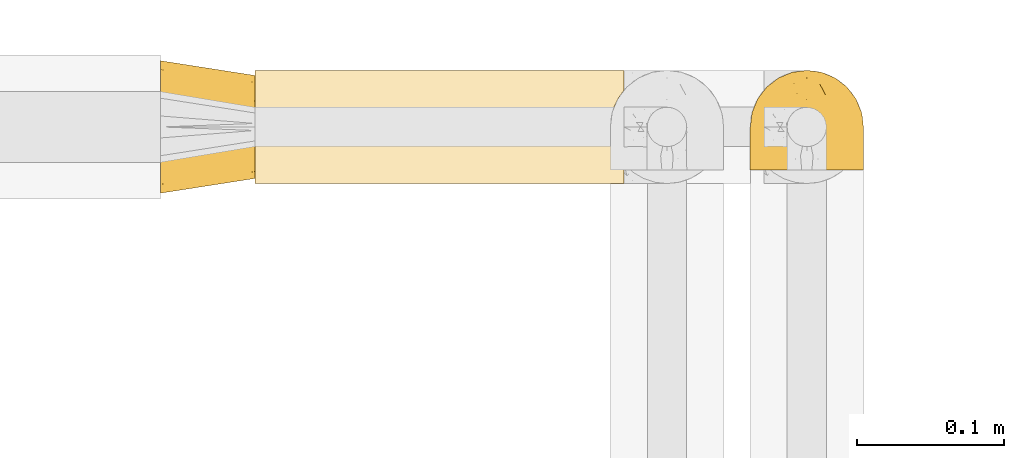
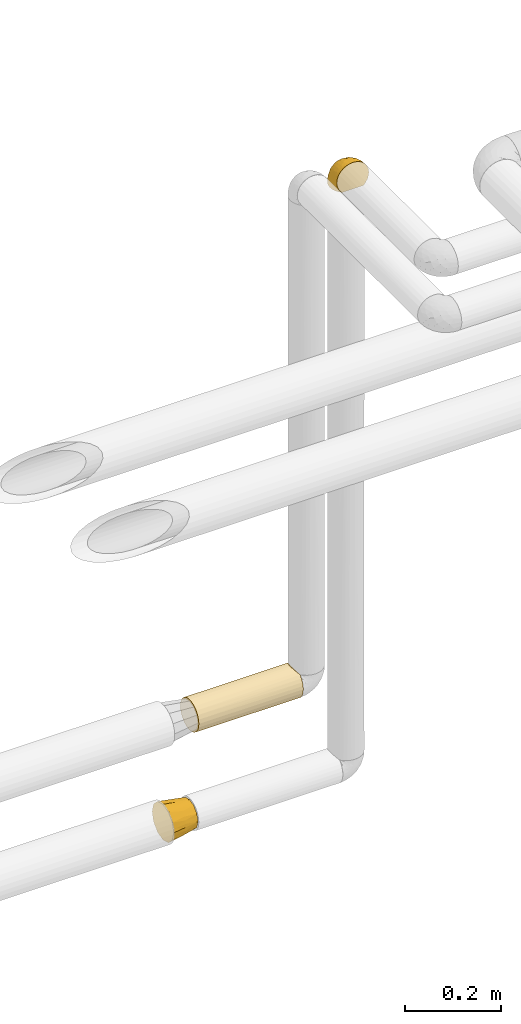
# One storey, part 368 of 827: 3 coverings.
"""IFC2X3 building model written with IfcOpenShell, lengths in millimetres."""

from ifc_helpers import new_model, entity, si_unit, converted_unit, derived_unit, direction, frame, origin, place, context, subcontext, project, spatial, faceted_brep, element, save


model = new_model("IFC2X3")

# Units and contexts
model_context = context("Model", 3, precision=0.01, world=origin(), true_north=direction((6.12303176911189e-17, 1.0)))
body_context = subcontext(model_context, "Body", "Model", "MODEL_VIEW")
ifc_project = project(units=[si_unit("LENGTHUNIT", "METRE", prefix="MILLI"), si_unit("AREAUNIT", "SQUARE_METRE"), si_unit("VOLUMEUNIT", "CUBIC_METRE"), converted_unit("PLANEANGLEUNIT", "DEGREE", entity("IfcRatioMeasure", 0.0174532925199433), si_unit("PLANEANGLEUNIT", "RADIAN"), dimensions=[0, 0, 0, 0, 0, 0, 0]), si_unit("MASSUNIT", "GRAM", prefix="KILO"), derived_unit("MASSDENSITYUNIT", [(si_unit("MASSUNIT", "GRAM", prefix="KILO"), 1), (si_unit("LENGTHUNIT", "METRE"), -3)]), derived_unit("MOMENTOFINERTIAUNIT", [(si_unit("LENGTHUNIT", "METRE"), 4)]), si_unit("TIMEUNIT", "SECOND"), si_unit("FREQUENCYUNIT", "HERTZ"), si_unit("THERMODYNAMICTEMPERATUREUNIT", "DEGREE_CELSIUS"), derived_unit("THERMALTRANSMITTANCEUNIT", [(si_unit("MASSUNIT", "GRAM", prefix="KILO"), 1), (si_unit("THERMODYNAMICTEMPERATUREUNIT", "KELVIN"), -1), (si_unit("TIMEUNIT", "SECOND"), -3)]), derived_unit("VOLUMETRICFLOWRATEUNIT", [(si_unit("LENGTHUNIT", "METRE"), 3), (si_unit("TIMEUNIT", "SECOND"), -1)]), derived_unit("MASSFLOWRATEUNIT", [(si_unit("MASSUNIT", "GRAM", prefix="KILO"), 1), (si_unit("TIMEUNIT", "SECOND"), -1)]), derived_unit("ROTATIONALFREQUENCYUNIT", [(si_unit("TIMEUNIT", "SECOND"), -1)]), si_unit("ELECTRICCURRENTUNIT", "AMPERE"), si_unit("ELECTRICVOLTAGEUNIT", "VOLT"), si_unit("POWERUNIT", "WATT"), si_unit("FORCEUNIT", "NEWTON", prefix="KILO"), si_unit("ILLUMINANCEUNIT", "LUX"), si_unit("LUMINOUSFLUXUNIT", "LUMEN"), si_unit("LUMINOUSINTENSITYUNIT", "CANDELA"), derived_unit("USERDEFINED", [(si_unit("MASSUNIT", "GRAM", prefix="KILO"), -1), (si_unit("LENGTHUNIT", "METRE"), -2), (si_unit("TIMEUNIT", "SECOND"), 3), (si_unit("LUMINOUSFLUXUNIT", "LUMEN"), 1)]), derived_unit("LINEARVELOCITYUNIT", [(si_unit("LENGTHUNIT", "METRE"), 1), (si_unit("TIMEUNIT", "SECOND"), -1)]), si_unit("PRESSUREUNIT", "PASCAL"), derived_unit("USERDEFINED", [(si_unit("LENGTHUNIT", "METRE"), -2), (si_unit("MASSUNIT", "GRAM", prefix="KILO"), 1), (si_unit("TIMEUNIT", "SECOND"), -2)]), derived_unit("LINEARFORCEUNIT", [(si_unit("MASSUNIT", "GRAM", prefix="KILO"), 1), (si_unit("LENGTHUNIT", "METRE"), 1), (si_unit("TIMEUNIT", "SECOND"), -2), (si_unit("LENGTHUNIT", "METRE"), -1)]), derived_unit("PLANARFORCEUNIT", [(si_unit("MASSUNIT", "GRAM", prefix="KILO"), 1), (si_unit("LENGTHUNIT", "METRE"), 1), (si_unit("TIMEUNIT", "SECOND"), -2), (si_unit("LENGTHUNIT", "METRE"), -2)])], contexts=[model_context])

# Site, building, storey
site_placement = place(None, origin())
site = spatial("IfcSite", under=ifc_project, at=site_placement, CompositionType="ELEMENT")
building_placement = place(site_placement, origin())
building = spatial("IfcBuilding", under=site, at=building_placement, CompositionType="ELEMENT")
storey_placement = place(building_placement, frame((0.0, 0.0, 28200.0)))
storey = spatial("IfcBuildingStorey", under=building, at=storey_placement, Name="08", CompositionType="ELEMENT", Elevation=28200.0)

# Coverings
covering_1_placement = place(storey_placement, frame((36309.98, 19463.91, 3169.3)))
element("IfcCovering", 1, at=covering_1_placement, inside=storey, Name=":ADSK_", ObjectType=":ADSK_", PredefinedType="INSULATION", context=body_context, shape_type="Brep", body=[
    faceted_brep([(74.68, 1.6, 47.38), (70.1, 1.6, 54.67), (64.01, 1.6, 60.76), (56.72, 1.6, 65.34), (48.6, 1.6, 68.18), (40.05, 1.6, 69.15), (31.49, 1.6, 68.18), (23.36, 1.6, 65.33), (16.07, 1.6, 60.75), (9.98, 1.6, 54.66), (5.4, 1.6, 47.37), (2.56, 1.6, 39.25), (1.6, 1.6, 30.7), (2.46, 1.6, 22.59), (5.01, 1.6, 14.86), (9.13, 1.6, 7.84), (14.62, 1.6, 1.85), (16.82, 1.6, 1.85), (18.56, 1.6, 1.85), (20.52, 1.6, 1.85), (22.49, 1.6, 1.85), (24.46, 1.6, 1.85), (26.42, 1.6, 1.85), (28.39, 1.6, 1.85), (30.36, 1.6, 1.85), (32.55, 1.6, 1.85), (34.75, 1.6, 1.85), (36.94, 1.6, 1.85), (39.13, 1.6, 1.85), (41.33, 1.6, 1.85), (43.52, 1.6, 1.85), (45.72, 1.6, 1.85), (47.91, 1.6, 1.85), (50.11, 1.6, 1.85), (52.3, 1.6, 1.85), (54.49, 1.6, 1.85), (56.69, 1.6, 1.85), (58.88, 1.6, 1.85), (61.08, 1.6, 1.85), (63.27, 1.6, 1.85), (65.47, 1.6, 1.85), (70.97, 1.6, 7.85), (75.09, 1.6, 14.88), (77.64, 1.6, 22.61), (78.5, 1.6, 30.7), (77.53, 1.6, 39.26), (14.62, 1.85, 1.6), (9.12, 7.85, 1.6), (5.0, 14.87, 1.6), (2.46, 22.6, 1.6), (1.6, 30.7, 1.6), (2.91, 40.65, 1.6), (6.75, 49.92, 1.6), (12.86, 57.88, 1.6), (20.82, 63.99, 1.6), (30.09, 67.84, 1.6), (40.05, 69.15, 1.6), (50.0, 67.84, 1.6), (59.27, 63.99, 1.6), (67.23, 57.88, 1.6), (73.34, 49.92, 1.6), (77.19, 40.65, 1.6), (78.5, 30.7, 1.6), (77.63, 22.6, 1.6), (75.09, 14.87, 1.6), (70.97, 7.85, 1.6), (65.47, 1.85, 1.6), (63.27, 1.85, 1.6), (62.29, 1.85, 1.6), (60.7, 1.85, 1.6), (59.11, 1.85, 1.6), (57.52, 1.85, 1.6), (55.93, 1.85, 1.6), (54.34, 1.85, 1.6), (52.76, 1.85, 1.6), (51.17, 1.85, 1.6), (49.58, 1.85, 1.6), (47.99, 1.85, 1.6), (46.4, 1.85, 1.6), (44.81, 1.85, 1.6), (43.22, 1.85, 1.6), (41.63, 1.85, 1.6), (40.05, 1.85, 1.6), (38.46, 1.85, 1.6), (36.87, 1.85, 1.6), (35.28, 1.85, 1.6), (33.69, 1.85, 1.6), (32.1, 1.85, 1.6), (30.51, 1.85, 1.6), (28.92, 1.85, 1.6), (27.33, 1.85, 1.6), (25.37, 1.85, 1.6), (23.4, 1.85, 1.6), (21.21, 1.85, 1.6), (19.01, 1.85, 1.6), (16.82, 1.85, 1.6), (42.32, 1.77, 1.78), (44.02, 1.78, 1.77), (47.13, 1.77, 1.78), (48.74, 1.77, 1.77), (23.57, 1.76, 1.79), (25.13, 1.77, 1.78), (61.34, 1.79, 1.76), (22.02, 1.78, 1.77), (29.72, 1.78, 1.77), (56.73, 1.78, 1.76), (55.14, 1.78, 1.77), (37.66, 1.78, 1.77), (64.12, 1.74, 1.8), (28.13, 1.78, 1.76), (26.62, 1.78, 1.77), (31.46, 1.77, 1.78), (16.16, 1.78, 1.77), (39.16, 1.78, 1.77), (50.37, 1.78, 1.76), (17.69, 1.77, 1.77), (19.17, 1.77, 1.78), (62.78, 1.77, 1.77), (58.35, 1.78, 1.77), (45.53, 1.78, 1.77), (59.91, 1.77, 1.78), (65.47, 1.77, 1.77), (65.47, 1.72, 1.8), (65.47, 1.66, 1.82), (14.62, 1.77, 1.77), (14.62, 1.8, 1.72), (14.62, 1.82, 1.66), (20.59, 1.79, 1.76), (32.99, 1.78, 1.77), (34.48, 1.79, 1.76), (51.91, 1.78, 1.77), (65.47, 1.82, 1.66), (65.47, 1.8, 1.72), (53.48, 1.76, 1.78), (14.62, 1.66, 1.82), (14.62, 1.72, 1.8), (40.77, 1.78, 1.77), (35.97, 1.77, 1.78), (7.84, 9.41, 3.72), (3.53, 17.65, 7.41), (8.32, 7.41, 6.13), (2.19, 15.21, 19.34), (3.53, 7.41, 17.64), (1.6, 16.15, 26.8), (1.6, 28.75, 8.87), (4.57, 13.67, 9.2), (3.96, 12.79, 12.79), (2.28, 19.18, 14.62), (1.6, 29.16, 7.34), (7.69, 9.04, 5.33), (8.32, 5.74, 7.7), (7.84, 3.72, 9.41), (1.6, 8.87, 28.75), (1.6, 21.47, 21.47), (1.6, 26.8, 16.15), (4.34, 9.53, 14.14), (1.6, 7.34, 29.16), (29.63, 37.63, 57.02), (27.34, 17.92, 64.92), (40.05, 27.45, 64.0), (2.39, 37.01, 11.92), (2.43, 34.22, 19.16), (9.07, 45.87, 28.65), (16.64, 56.57, 24.62), (9.54, 52.31, 15.19), (4.52, 42.07, 18.36), (4.52, 44.74, 9.2), (7.49, 21.49, 46.98), (7.49, 11.02, 50.24), (12.85, 15.64, 56.1), (2.35, 26.02, 28.97), (22.66, 36.59, 54.46), (32.9, 65.49, 21.34), (25.33, 63.99, 18.4), (40.05, 15.2, 66.44), (16.64, 60.27, 12.07), (19.99, 45.25, 45.49), (16.37, 35.21, 50.57), (3.26, 22.52, 36.04), (3.75, 12.03, 42.07), (19.58, 13.32, 62.12), (7.5, 35.9, 37.37), (4.04, 33.87, 29.39), (13.94, 25.73, 53.59), (19.58, 26.34, 58.06), (28.21, 46.78, 49.27), (24.75, 59.54, 29.63), (31.42, 60.18, 33.21), (26.2, 53.93, 40.1), (33.36, 53.36, 44.08), (40.05, 49.36, 49.36), (40.05, 38.4, 56.68), (40.05, 66.44, 15.2), (16.14, 50.09, 35.57), (12.85, 41.08, 41.7), (10.47, 31.14, 46.4), (6.49, 28.19, 41.41), (40.05, 64.0, 27.45), (40.05, 56.68, 38.4), (75.57, 43.9, 12.99), (47.37, 65.46, 21.33), (52.91, 52.22, 42.89), (50.46, 37.61, 57.04), (67.23, 15.64, 56.11), (60.5, 13.31, 62.13), (70.55, 50.02, 21.89), (63.45, 59.28, 16.62), (62.61, 53.05, 32.9), (72.6, 21.48, 46.99), (72.6, 11.01, 50.25), (76.34, 12.03, 42.08), (59.34, 41.02, 49.91), (77.76, 35.39, 15.6), (78.5, 26.8, 16.15), (78.5, 28.75, 8.87), (78.5, 7.34, 29.16), (53.16, 65.81, 13.16), (70.55, 53.28, 10.83), (48.88, 59.8, 33.8), (54.76, 61.82, 25.02), (52.74, 17.91, 64.92), (71.93, 41.4, 32.83), (75.79, 40.48, 20.56), (60.5, 26.34, 58.07), (77.86, 31.68, 21.46), (77.64, 27.68, 28.1), (78.5, 16.15, 26.8), (78.5, 21.47, 21.47), (67.23, 28.05, 51.29), (76.82, 22.54, 36.04), (78.5, 8.87, 28.75), (77.8, 37.3, 8.45), (67.23, 41.07, 41.73), (73.2, 32.24, 39.27), (67.66, 47.4, 33.56), (75.99, 35.77, 27.29), (76.57, 17.65, 7.41), (73.21, 11.06, 3.51), (71.93, 8.55, 4.68), (71.07, 6.63, 5.52), (75.09, 12.77, 8.75), (76.13, 12.79, 12.79), (76.57, 7.41, 17.65), (77.69, 18.97, 13.9), (72.26, 3.72, 9.42), (71.77, 5.76, 7.68), (77.9, 15.21, 19.33), (75.75, 9.52, 14.13)], [[[0, 1, 2, 3, 4, 5, 6, 7, 8, 9, 10, 11, 12, 13, 14, 15, 16, 17, 18, 19, 20, 21, 22, 23, 24, 25, 26, 27, 28, 29, 30, 31, 32, 33, 34, 35, 36, 37, 38, 39, 40, 41, 42, 43, 44, 45]], [[46, 47, 48, 49, 50, 51, 52, 53, 54, 55, 56, 57, 58, 59, 60, 61, 62, 63, 64, 65, 66, 67, 68, 69, 70, 71, 72, 73, 74, 75, 76, 77, 78, 79, 80, 81, 82, 83, 84, 85, 86, 87, 88, 89, 90, 91, 92, 93, 94, 95]], [[96, 97, 30]], [[98, 77, 99]], [[100, 101, 21]], [[69, 68, 102]], [[20, 19, 103]], [[24, 23, 104]], [[20, 103, 100]], [[72, 105, 106]], [[84, 83, 107]], [[89, 88, 104]], [[108, 67, 66]], [[109, 110, 90]], [[111, 25, 24]], [[112, 17, 16]], [[82, 113, 83]], [[109, 23, 22]], [[114, 76, 75]], [[105, 36, 106]], [[104, 111, 24]], [[18, 115, 116]], [[97, 96, 80]], [[67, 108, 117]], [[105, 71, 118]], [[31, 97, 119]], [[102, 120, 69]], [[108, 121, 122, 123, 40]], [[112, 95, 115]], [[17, 115, 18]], [[94, 116, 115]], [[117, 68, 67]], [[38, 117, 39]], [[112, 124, 125, 126, 46]], [[17, 112, 115]], [[70, 120, 118]], [[39, 117, 108]], [[120, 38, 37]], [[120, 37, 118]], [[120, 70, 69]], [[116, 94, 127]], [[128, 86, 129]], [[117, 38, 102]], [[74, 130, 75]], [[99, 33, 32]], [[115, 95, 94]], [[39, 108, 40]], [[108, 66, 131, 132, 121]], [[105, 72, 71]], [[118, 37, 36]], [[71, 70, 118]], [[35, 106, 36]], [[36, 105, 118]], [[35, 133, 106]], [[74, 73, 133]], [[106, 133, 73]], [[99, 114, 33]], [[133, 35, 34]], [[73, 72, 106]], [[95, 112, 46]], [[112, 16, 134, 135, 124]], [[130, 114, 75]], [[99, 76, 114]], [[114, 130, 33]], [[34, 33, 130]], [[78, 77, 98]], [[98, 119, 78]], [[130, 133, 34]], [[133, 130, 74]], [[79, 97, 80]], [[98, 99, 32]], [[98, 32, 31]], [[77, 76, 99]], [[97, 79, 119]], [[136, 96, 29]], [[30, 97, 31]], [[136, 29, 28]], [[81, 80, 96]], [[29, 96, 30]], [[31, 119, 98]], [[119, 79, 78]], [[96, 136, 81]], [[82, 81, 136]], [[113, 107, 83]], [[84, 107, 137]], [[107, 27, 137]], [[113, 28, 107]], [[27, 107, 28]], [[85, 84, 137]], [[137, 27, 26]], [[113, 136, 28]], [[136, 113, 82]], [[109, 89, 104]], [[86, 85, 129]], [[89, 109, 90]], [[111, 87, 128]], [[26, 129, 137]], [[88, 111, 104]], [[25, 111, 128]], [[22, 110, 109]], [[23, 109, 104]], [[110, 91, 90]], [[100, 92, 101]], [[110, 22, 101]], [[91, 110, 101]], [[116, 19, 18]], [[111, 88, 87]], [[127, 103, 19]], [[25, 128, 26]], [[86, 128, 87]], [[128, 129, 26]], [[137, 129, 85]], [[120, 102, 38]], [[117, 102, 68]], [[91, 101, 92]], [[21, 101, 22]], [[93, 92, 103]], [[100, 21, 20]], [[100, 103, 92]], [[127, 93, 103]], [[93, 127, 94]], [[116, 127, 19]], [[126, 138, 47]], [[48, 138, 139]], [[140, 125, 124]], [[141, 142, 143]], [[144, 49, 139]], [[145, 140, 146]], [[48, 139, 49]], [[139, 145, 147]], [[49, 144, 148, 50]], [[126, 125, 149]], [[14, 13, 142]], [[150, 146, 140]], [[149, 140, 145]], [[151, 150, 135]], [[151, 14, 142]], [[16, 15, 134]], [[13, 152, 142]], [[124, 150, 140]], [[141, 143, 153]], [[14, 151, 15]], [[15, 151, 134]], [[47, 46, 126]], [[139, 154, 144]], [[138, 48, 47]], [[125, 140, 149]], [[135, 134, 151]], [[146, 155, 141]], [[145, 146, 147]], [[149, 139, 138]], [[147, 153, 154]], [[147, 146, 141]], [[139, 147, 154]], [[139, 149, 145]], [[149, 138, 126]], [[147, 141, 153]], [[146, 150, 155]], [[151, 155, 150]], [[142, 141, 155]], [[13, 12, 156, 152]], [[152, 143, 142]], [[151, 142, 155]], [[150, 124, 135]], [[157, 158, 159]], [[160, 154, 161]], [[162, 163, 164]], [[165, 166, 160]], [[167, 168, 169]], [[153, 170, 161]], [[156, 12, 11]], [[158, 157, 171]], [[172, 55, 173]], [[158, 6, 174]], [[175, 54, 53]], [[52, 166, 164]], [[52, 164, 53]], [[54, 175, 173]], [[166, 52, 51]], [[176, 177, 171]], [[178, 143, 179]], [[156, 11, 179]], [[8, 7, 180]], [[169, 9, 8]], [[179, 143, 152, 156]], [[179, 11, 10]], [[168, 179, 10]], [[181, 162, 182]], [[179, 167, 178]], [[183, 184, 177]], [[183, 169, 184]], [[176, 171, 185]], [[172, 186, 187]], [[158, 7, 6]], [[159, 158, 174]], [[184, 180, 158]], [[54, 173, 55]], [[180, 169, 8]], [[188, 189, 187]], [[9, 168, 10]], [[186, 188, 187]], [[190, 157, 159, 191]], [[55, 172, 192]], [[176, 193, 194]], [[161, 170, 182]], [[162, 164, 165]], [[175, 164, 163]], [[51, 50, 148]], [[167, 195, 196]], [[178, 182, 170]], [[6, 5, 174]], [[158, 180, 7]], [[169, 180, 184]], [[169, 168, 9]], [[179, 168, 167]], [[182, 162, 165]], [[162, 194, 193]], [[161, 165, 160]], [[195, 181, 196]], [[192, 172, 197]], [[192, 56, 55]], [[189, 190, 198]], [[198, 197, 187]], [[172, 187, 197]], [[185, 189, 188]], [[198, 187, 189]], [[186, 172, 173]], [[173, 163, 186]], [[193, 186, 163]], [[176, 185, 188]], [[185, 157, 190]], [[188, 186, 193]], [[177, 176, 194]], [[188, 193, 176]], [[162, 193, 163]], [[195, 177, 194]], [[171, 177, 184]], [[181, 195, 194]], [[183, 167, 169]], [[162, 181, 194]], [[196, 182, 178]], [[158, 171, 184]], [[171, 157, 185]], [[177, 195, 183]], [[167, 183, 195]], [[182, 196, 181]], [[178, 170, 143]], [[178, 167, 196]], [[164, 175, 53]], [[173, 175, 163]], [[160, 51, 148]], [[164, 166, 165]], [[51, 160, 166]], [[160, 148, 144, 154]], [[153, 161, 154]], [[182, 165, 161]], [[190, 189, 185]], [[143, 170, 153]], [[60, 199, 61]], [[197, 200, 192]], [[201, 190, 202]], [[200, 57, 192]], [[203, 204, 2]], [[205, 206, 207]], [[208, 209, 210]], [[211, 207, 201]], [[212, 213, 214]], [[45, 215, 210]], [[216, 206, 58]], [[45, 44, 215]], [[59, 217, 60]], [[60, 217, 199]], [[0, 45, 210]], [[218, 201, 219]], [[202, 159, 220]], [[205, 221, 222]], [[223, 204, 203]], [[1, 203, 2]], [[57, 200, 216]], [[220, 3, 204]], [[220, 174, 4]], [[1, 0, 209]], [[212, 224, 213]], [[225, 226, 227]], [[228, 223, 203]], [[208, 210, 229]], [[210, 226, 229]], [[3, 220, 4]], [[58, 206, 59]], [[209, 203, 1]], [[202, 220, 223]], [[228, 203, 208]], [[202, 211, 201]], [[3, 2, 204]], [[202, 190, 191, 159]], [[210, 215, 230, 226]], [[199, 212, 231]], [[232, 233, 221]], [[233, 208, 229]], [[207, 206, 219]], [[217, 206, 205]], [[227, 224, 225]], [[233, 232, 228]], [[201, 207, 219]], [[234, 232, 221]], [[218, 219, 200]], [[202, 223, 211]], [[174, 220, 159]], [[174, 5, 4]], [[61, 231, 62]], [[220, 204, 223]], [[210, 209, 0]], [[203, 209, 208]], [[225, 233, 229]], [[224, 227, 213]], [[221, 233, 235]], [[57, 56, 192]], [[198, 218, 197]], [[200, 219, 216]], [[201, 198, 190]], [[197, 218, 200]], [[198, 201, 218]], [[206, 216, 219]], [[58, 57, 216]], [[231, 212, 214]], [[222, 212, 199]], [[228, 211, 223]], [[207, 211, 232]], [[62, 231, 214]], [[199, 231, 61]], [[233, 228, 208]], [[211, 228, 232]], [[222, 221, 235]], [[234, 205, 207]], [[206, 217, 59]], [[199, 217, 205]], [[205, 222, 199]], [[224, 222, 235]], [[222, 224, 212]], [[224, 235, 225]], [[233, 225, 235]], [[226, 225, 229]], [[205, 234, 221]], [[207, 232, 234]], [[63, 214, 236]], [[214, 213, 236]], [[214, 63, 62]], [[237, 236, 238]], [[238, 132, 131]], [[236, 237, 64]], [[239, 240, 241]], [[63, 236, 64]], [[131, 66, 65]], [[237, 131, 65]], [[242, 230, 43]], [[237, 65, 64]], [[239, 121, 132]], [[42, 242, 43]], [[241, 240, 243]], [[41, 123, 244]], [[43, 230, 215, 44]], [[244, 122, 245]], [[227, 246, 243]], [[245, 241, 247]], [[121, 239, 245]], [[41, 40, 123]], [[132, 238, 239]], [[244, 42, 41]], [[131, 237, 238]], [[240, 239, 238]], [[245, 239, 241]], [[247, 241, 246]], [[247, 244, 245]], [[238, 236, 240]], [[243, 236, 213]], [[236, 243, 240]], [[246, 241, 243]], [[243, 213, 227]], [[226, 242, 246]], [[227, 226, 246]], [[246, 242, 247]], [[244, 247, 242]], [[242, 226, 230]], [[42, 244, 242]], [[122, 244, 123]], [[122, 121, 245]]]),
])
covering_2_placement = place(storey_placement, frame((35911.02, 19448.01, 1653.4)))
element("IfcCovering", 2, at=covering_2_placement, inside=storey, Name=":ADSK_", ObjectType=":ADSK_", PredefinedType="INSULATION", context=body_context, shape_type="Brep", body=[
    faceted_brep([(0.0, 77.33, 77.33), (0.0, 85.57, 69.1), (0.0, 88.58, 57.85), (0.0, 91.6, 46.6), (0.0, 89.4, 38.39), (0.0, 85.57, 24.1), (0.0, 77.33, 15.86), (0.0, 69.1, 7.62), (0.0, 57.85, 4.61), (0.0, 46.6, 1.6), (0.0, 38.39, 3.79), (0.0, 24.1, 7.62), (0.0, 15.86, 15.86), (0.0, 7.62, 24.1), (0.0, 4.61, 35.35), (0.0, 1.6, 46.6), (0.0, 3.79, 54.8), (0.0, 7.62, 69.1), (0.0, 15.86, 77.33), (0.0, 24.1, 85.57), (0.0, 35.35, 88.58), (0.0, 46.6, 91.6), (0.0, 54.8, 89.4), (0.0, 69.1, 85.57), (64.0, 81.6, 46.6), (64.0, 79.25, 55.35), (64.0, 76.91, 64.1), (64.0, 70.5, 70.5), (64.0, 64.1, 76.91), (64.0, 55.35, 79.25), (64.0, 46.6, 81.6), (64.0, 37.85, 79.25), (64.0, 29.1, 76.91), (64.0, 22.69, 70.5), (64.0, 16.28, 64.1), (64.0, 13.94, 55.35), (64.0, 11.6, 46.6), (64.0, 13.94, 37.85), (64.0, 16.28, 29.1), (64.0, 22.69, 22.69), (64.0, 29.1, 16.28), (64.0, 37.85, 13.94), (64.0, 46.6, 11.6), (64.0, 55.35, 13.94), (64.0, 64.1, 16.28), (64.0, 70.5, 22.69), (64.0, 76.91, 29.1), (64.0, 79.25, 37.85), (32.0, 83.55, 31.29), (33.41, 85.61, 38.84), (31.52, 86.67, 46.6), (32.0, 79.57, 23.95), (32.0, 63.83, 10.5), (32.0, 70.95, 14.86), (31.52, 46.6, 6.52), (32.0, 56.54, 7.85), (32.0, 31.29, 9.64), (33.41, 38.84, 7.58), (32.0, 23.95, 13.62), (32.0, 10.5, 29.36), (32.0, 14.86, 22.24), (31.52, 6.52, 46.6), (32.0, 7.85, 36.65), (32.0, 9.64, 61.9), (33.41, 7.58, 54.35), (32.0, 13.62, 69.24), (32.0, 29.36, 82.69), (32.0, 22.24, 78.33), (31.52, 46.6, 86.67), (32.0, 36.65, 85.34), (32.0, 61.9, 83.55), (33.41, 54.35, 85.61), (32.0, 69.24, 79.57), (32.0, 82.69, 63.83), (32.0, 78.33, 70.95), (32.0, 85.34, 56.54)], [[[0, 1, 2, 3, 4, 5, 6, 7, 8, 9, 10, 11, 12, 13, 14, 15, 16, 17, 18, 19, 20, 21, 22, 23]], [[24, 25, 26, 27, 28, 29, 30, 31, 32, 33, 34, 35, 36, 37, 38, 39, 40, 41, 42, 43, 44, 45, 46, 47]], [[48, 47, 46]], [[49, 4, 50]], [[4, 3, 50]], [[49, 24, 47]], [[51, 5, 48]], [[51, 46, 45]], [[52, 7, 53]], [[52, 53, 44]], [[49, 47, 48]], [[54, 9, 55, 42]], [[4, 48, 5]], [[53, 51, 45]], [[6, 51, 53]], [[51, 48, 46]], [[44, 53, 45]], [[6, 5, 51]], [[7, 6, 53]], [[4, 49, 48]], [[43, 55, 52]], [[52, 44, 43]], [[55, 8, 52]], [[8, 7, 52]], [[8, 55, 9]], [[24, 49, 50]], [[42, 55, 43]], [[56, 41, 40]], [[57, 10, 54]], [[10, 9, 54]], [[57, 42, 41]], [[58, 11, 56]], [[58, 40, 39]], [[59, 13, 60]], [[59, 60, 38]], [[57, 41, 56]], [[61, 15, 62, 36]], [[10, 56, 11]], [[60, 58, 39]], [[12, 58, 60]], [[58, 56, 40]], [[38, 60, 39]], [[12, 11, 58]], [[13, 12, 60]], [[10, 57, 56]], [[37, 62, 59]], [[59, 38, 37]], [[62, 14, 59]], [[14, 13, 59]], [[14, 62, 15]], [[42, 57, 54]], [[36, 62, 37]], [[63, 35, 34]], [[64, 16, 61]], [[16, 15, 61]], [[64, 36, 35]], [[65, 17, 63]], [[65, 34, 33]], [[66, 19, 67]], [[66, 67, 32]], [[64, 35, 63]], [[68, 21, 69, 30]], [[16, 63, 17]], [[67, 65, 33]], [[18, 65, 67]], [[65, 63, 34]], [[32, 67, 33]], [[18, 17, 65]], [[19, 18, 67]], [[16, 64, 63]], [[31, 69, 66]], [[66, 32, 31]], [[69, 20, 66]], [[20, 19, 66]], [[20, 69, 21]], [[36, 64, 61]], [[30, 69, 31]], [[70, 29, 28]], [[71, 22, 68]], [[22, 21, 68]], [[71, 30, 29]], [[72, 23, 70]], [[72, 28, 27]], [[73, 1, 74]], [[73, 74, 26]], [[71, 29, 70]], [[50, 3, 75, 24]], [[22, 70, 23]], [[74, 72, 27]], [[0, 72, 74]], [[72, 70, 28]], [[26, 74, 27]], [[0, 23, 72]], [[1, 0, 74]], [[22, 71, 70]], [[25, 75, 73]], [[73, 26, 25]], [[75, 2, 73]], [[2, 1, 73]], [[2, 75, 3]], [[30, 71, 68]], [[24, 75, 25]]]),
])
covering_3_placement = place(storey_placement, frame((35975.02, 19454.61, 1910.0)))
element("IfcCovering", 3, at=covering_3_placement, inside=storey, Name=":ADSK_", ObjectType=":ADSK_", PredefinedType="INSULATION", context=body_context, shape_type="Brep", body=[
    faceted_brep([(250.9, 73.25, 20.8), (250.9, 77.09, 30.06), (250.9, 78.4, 40.0), (250.9, 77.51, 48.2), (250.9, 74.9, 56.01), (250.9, 70.68, 63.08), (250.9, 65.05, 69.1), (250.9, 14.94, 69.1), (250.9, 9.31, 63.08), (250.9, 5.09, 56.01), (250.9, 2.48, 48.2), (250.9, 1.6, 40.0), (250.9, 2.9, 30.06), (250.9, 6.74, 20.8), (250.9, 12.84, 12.84), (250.9, 20.8, 6.74), (250.9, 30.06, 2.9), (250.9, 40.0, 1.6), (250.9, 49.93, 2.9), (250.9, 59.2, 6.74), (250.9, 67.15, 12.84), (0.0, 73.25, 20.8), (0.0, 67.15, 12.84), (0.0, 59.2, 6.74), (0.0, 49.93, 2.9), (0.0, 40.0, 1.6), (0.0, 30.06, 2.9), (0.0, 20.8, 6.74), (0.0, 12.84, 12.84), (0.0, 6.74, 20.8), (0.0, 2.9, 30.06), (0.0, 1.6, 40.0), (0.0, 2.9, 49.93), (0.0, 6.74, 59.2), (0.0, 12.84, 67.15), (0.0, 20.8, 73.25), (0.0, 30.06, 77.09), (0.0, 40.0, 78.4), (0.0, 49.93, 77.09), (0.0, 59.2, 73.25), (0.0, 67.15, 67.15), (0.0, 73.25, 59.2), (0.0, 77.09, 49.93), (0.0, 78.4, 40.0), (0.0, 77.09, 30.06), (244.0, 53.36, 76.0), (242.2, 46.78, 77.79), (241.6, 40.0, 78.4), (246.93, 59.51, 73.07), (242.2, 33.21, 77.79), (244.0, 26.63, 76.0), (246.93, 20.48, 73.07)], [[[0, 1, 2, 3, 4, 5, 6, 7, 8, 9, 10, 11, 12, 13, 14, 15, 16, 17, 18, 19, 20]], [[21, 22, 23, 24, 25, 26, 27, 28, 29, 30, 31, 32, 33, 34, 35, 36, 37, 38, 39, 40, 41, 42, 43, 44]], [[30, 29, 13, 12]], [[31, 30, 12, 11]], [[29, 28, 14, 13]], [[16, 15, 27, 26]], [[17, 16, 26, 25]], [[28, 27, 15, 14]], [[18, 17, 25, 24]], [[19, 18, 24, 23]], [[23, 22, 20, 19]], [[1, 0, 21, 44]], [[2, 1, 44, 43]], [[22, 21, 0, 20]], [[3, 43, 42]], [[4, 42, 41]], [[5, 41, 40]], [[2, 43, 3]], [[3, 42, 4]], [[41, 5, 4]], [[40, 6, 5]], [[45, 39, 38]], [[38, 37, 46]], [[47, 46, 37]], [[48, 6, 39]], [[46, 45, 38]], [[48, 39, 45]], [[39, 6, 40]], [[49, 47, 37]], [[49, 37, 36]], [[50, 36, 35]], [[50, 49, 36]], [[7, 51, 35]], [[50, 35, 51]], [[35, 34, 7]], [[8, 34, 33]], [[9, 33, 32]], [[10, 32, 31]], [[8, 33, 9]], [[9, 32, 10]], [[31, 11, 10]], [[34, 8, 7]], [[49, 50, 51, 7, 6, 48, 45, 46, 47]]]),
])

save(model, "model.ifc")
